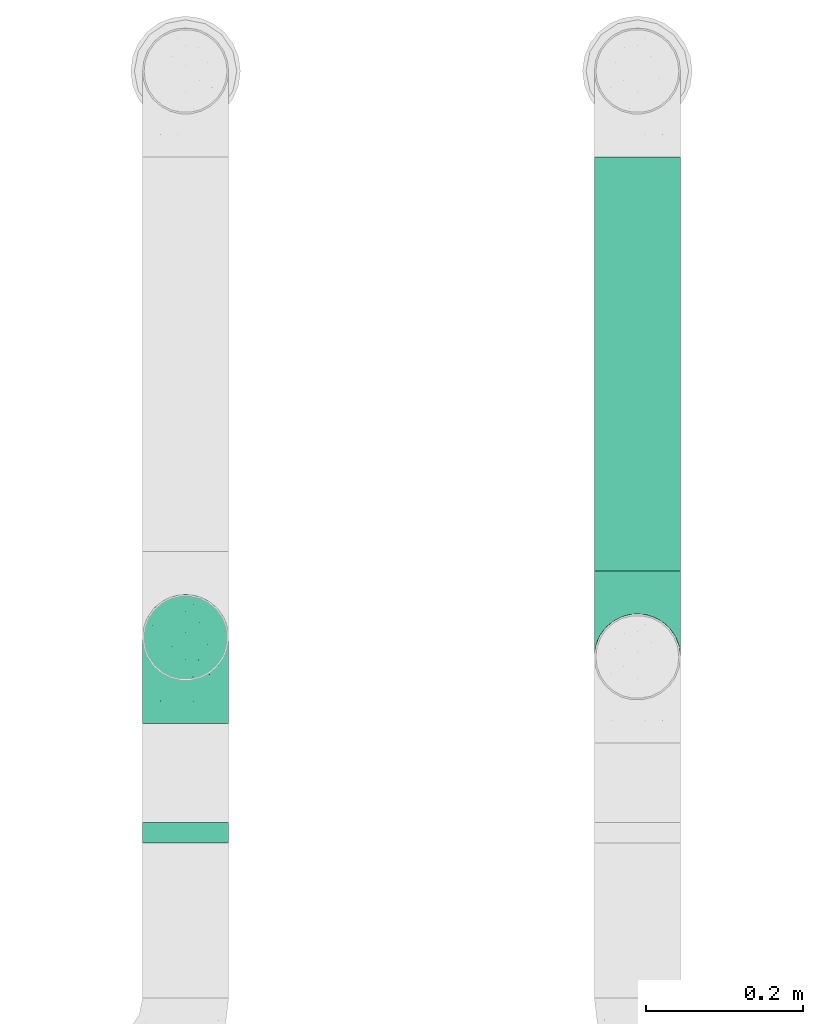
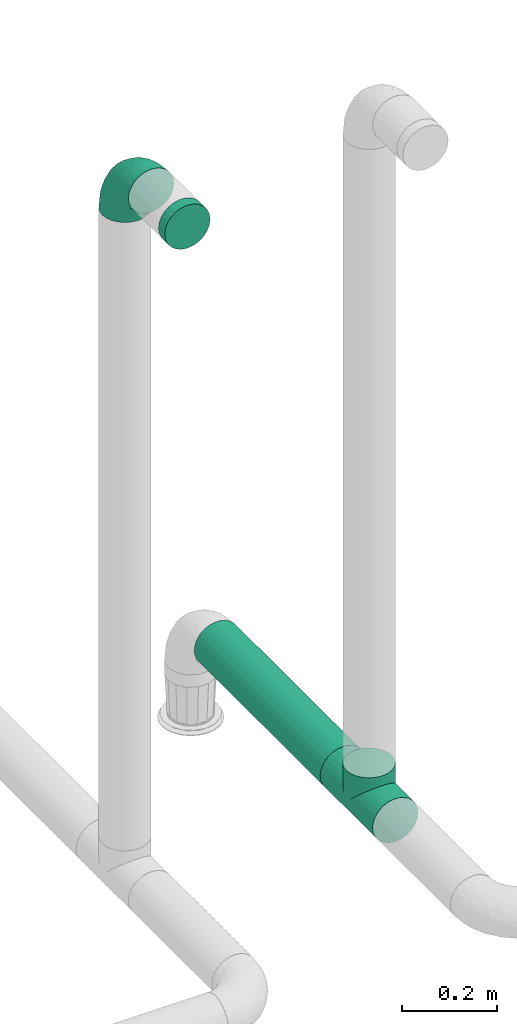
# One storey, part 59 of 103: 3 flow fittings, 1 flow segment.
"""IFC2X3 building model written with IfcOpenShell, lengths in millimetres."""

from ifc_helpers import new_model, entity, si_unit, converted_unit, derived_unit, direction, frame, origin_with_axes, origin_2d_with_axis, place, context, subcontext, project, spatial, hollow_circle, extrude, open_shell, surface_model, source, transform, mapped, material, layer, layer_set, layer_usage, type_object, element, save


model = new_model("IFC2X3")

# Units and contexts
model_context = context("Model", 3, precision=1e-05, world=origin_with_axes(), true_north=direction((0.0, 1.0)))
body_context = subcontext(model_context, "Body", "Model", "MODEL_VIEW")
ifc_project = project(units=[si_unit("AREAUNIT", "SQUARE_METRE"), si_unit("VOLUMEUNIT", "CUBIC_METRE", prefix="DECI"), si_unit("TIMEUNIT", "SECOND"), si_unit("THERMODYNAMICTEMPERATUREUNIT", "DEGREE_CELSIUS"), si_unit("PRESSUREUNIT", "PASCAL"), si_unit("MASSUNIT", "GRAM", prefix="KILO"), si_unit("LENGTHUNIT", "METRE", prefix="MILLI"), si_unit("POWERUNIT", "WATT"), si_unit("ELECTRICCURRENTUNIT", "AMPERE"), si_unit("ELECTRICVOLTAGEUNIT", "VOLT"), derived_unit("VOLUMETRICFLOWRATEUNIT", [(si_unit("VOLUMEUNIT", "CUBIC_METRE", prefix="DECI"), 1), (si_unit("TIMEUNIT", "SECOND"), -1)]), derived_unit("LINEARVELOCITYUNIT", [(si_unit("LENGTHUNIT", "METRE"), 1), (si_unit("TIMEUNIT", "SECOND"), -1)]), derived_unit("MASSDENSITYUNIT", [(si_unit("MASSUNIT", "GRAM", prefix="KILO"), 1), (si_unit("VOLUMEUNIT", "CUBIC_METRE"), -1)]), converted_unit("PLANEANGLEUNIT", "DEGREE", entity("IfcRatioMeasure", 0.01745), si_unit("PLANEANGLEUNIT", "RADIAN"), dimensions=[0, 0, 0, 0, 0, 0, 0])], contexts=[model_context])

# Site, building, storey
site_placement = place(None, origin_with_axes())
site = spatial("IfcSite", under=ifc_project, at=site_placement, CompositionType="ELEMENT")
building_placement = place(site_placement, origin_with_axes())
building = spatial("IfcBuilding", under=site, at=building_placement, Name="mc-building", CompositionType="ELEMENT")
storey_placement = place(building_placement, frame((0.0, 0.0, 5900.0), z_axis=(0.0, 0.0, 1.0), x_axis=(1.0, 0.0, 0.0)))
storey = spatial("IfcBuildingStorey", under=building, at=storey_placement, Name="3. Korrus", CompositionType="ELEMENT", Elevation=5900.0)

# Flow fitting
duct_fitting_type_1 = type_object("IfcDuctFittingType", PredefinedType="JUNCTION")
shared_shape_1 = source(origin_with_axes(), body_context, "Body", "SurfaceModel", [
    surface_model("IfcShellBasedSurfaceModel", [(0.0, -80.0, -55.0), (14.23505, -80.0, -53.12592), (-14.23505, -80.0, -53.12592), (-53.12592, -80.0, 14.23505), (-27.5, -80.0, -47.63139), (-47.63139, -80.0, -27.5), (-38.89087, -80.0, -38.89087), (55.0, -80.0, 0.0), (53.12592, -80.0, 14.23505), (38.89087, -80.0, -38.89087), (27.5, -80.0, -47.63139), (53.12592, -80.0, -14.23505), (47.63139, -80.0, -27.5), (-53.12592, -80.0, -14.23505), (-47.63139, -80.0, 27.5), (-38.89087, -80.0, 38.89087), (14.23505, -80.0, 53.12592), (-27.5, -80.0, 47.63139), (-14.23505, -80.0, 53.12592), (47.63139, -80.0, 27.5), (38.89087, -80.0, 38.89087), (27.5, -80.0, 47.63139), (0.0, -80.0, 55.0), (-55.0, -80.0, 0.0), (0.0, 0.0, 55.0), (-7.4066, -7.4066, 54.49901), (-14.74521, -14.74521, 52.98659), (-21.93978, -21.93978, 50.43457), (-28.89905, -28.89905, 46.79578), (-35.50357, -35.50357, 42.00591), (-41.58668, -41.58668, 35.99373), (-46.92319, -46.92319, 28.69171), (-51.19777, -51.19777, 20.0945), (-50.37866, -80.0, 20.86752), (-54.01174, -54.01174, 10.37938), (-55.0, -55.0, 0.0), (-54.06296, -80.0, 7.11752), (-54.01174, -54.01174, -10.37938), (-51.19777, -51.19777, -20.0945), (-54.06296, -80.0, -7.11752), (-46.92319, -46.92319, -28.69171), (-41.58668, -41.58668, -35.99373), (-50.37866, -80.0, -20.86752), (-35.50357, -35.50357, -42.00591), (-21.93978, -21.93978, -50.43457), (-14.74521, -14.74521, -52.98659), (-7.4066, -7.4066, -54.49901), (0.0, 0.0, -55.0), (-28.89905, -28.89905, -46.79578), (7.4066, -7.4066, -54.49901), (14.74521, -14.74521, -52.98659), (21.93978, -21.93978, -50.43457), (28.89905, -28.89905, -46.79578), (35.50357, -35.50357, -42.00591), (41.58668, -41.58668, -35.99373), (46.92319, -46.92319, -28.69171), (51.19777, -51.19777, -20.0945), (50.37866, -80.0, -20.86752), (54.01174, -54.01174, -10.37938), (55.0, -55.0, 0.0), (54.06296, -80.0, -7.11752), (54.01174, -54.01174, 10.37938), (51.19777, -51.19777, 20.0945), (54.06296, -80.0, 7.11752), (46.92319, -46.92319, 28.69171), (41.58668, -41.58668, 35.99373), (50.37866, -80.0, 20.86752), (35.50357, -35.50357, 42.00591), (21.93978, -21.93978, 50.43457), (14.74521, -14.74521, 52.98659), (7.4066, -7.4066, 54.49901), (28.89905, -28.89905, 46.79578), (-110.0, 0.0, -55.0), (-110.0, -14.23505, -53.12592), (-110.0, 14.23505, -53.12592), (-110.0, 53.12592, 14.23505), (-110.0, 27.5, -47.63139), (-110.0, 47.63139, -27.5), (-110.0, 38.89087, -38.89087), (-110.0, -55.0, 0.0), (-110.0, -53.12592, 14.23505), (-110.0, -38.89087, -38.89087), (-110.0, -27.5, -47.63139), (-110.0, -53.12592, -14.23505), (-110.0, -47.63139, -27.5), (-110.0, 53.12592, -14.23505), (-110.0, 47.63139, 27.5), (-110.0, 38.89087, 38.89087), (-110.0, -14.23505, 53.12592), (-110.0, 27.5, 47.63139), (-110.0, 14.23505, 53.12592), (-110.0, -47.63139, 27.5), (-110.0, -38.89087, 38.89087), (-110.0, -27.5, 47.63139), (-110.0, 0.0, 55.0), (-110.0, 55.0, 0.0), (110.0, 55.0, 0.0), (110.0, 0.0, -55.0), (110.0, 14.23505, -53.12592), (110.0, 27.5, -47.63139), (110.0, 38.89087, -38.89087), (110.0, 47.63139, -27.5), (110.0, -38.89087, -38.89087), (110.0, -53.12592, 14.23505), (110.0, -27.5, -47.63139), (110.0, -14.23505, -53.12592), (110.0, -47.63139, -27.5), (110.0, -53.12592, -14.23505), (110.0, -55.0, 0.0), (110.0, 53.12592, -14.23505), (110.0, 53.12592, 14.23505), (110.0, 47.63139, 27.5), (110.0, 38.89087, 38.89087), (110.0, 0.0, 55.0), (110.0, 27.5, 47.63139), (110.0, 14.23505, 53.12592), (110.0, -47.63139, 27.5), (110.0, -38.89087, 38.89087), (110.0, -27.5, 47.63139), (110.0, -14.23505, 53.12592)], [open_shell([[[0, 1, 2]], [[2, 3, 4]], [[5, 6, 3]], [[6, 4, 3]], [[2, 7, 8]], [[9, 7, 10]], [[1, 10, 7]], [[11, 7, 12]], [[9, 12, 7]], [[7, 2, 1]], [[5, 3, 13]], [[2, 14, 3]], [[2, 15, 14]], [[2, 16, 17]], [[17, 15, 2]], [[16, 18, 17]], [[2, 8, 19]], [[2, 19, 20]], [[2, 20, 21]], [[16, 2, 21]], [[16, 22, 18]], [[23, 13, 3]], [[24, 25, 22]], [[26, 27, 18]], [[25, 26, 18]], [[22, 25, 18]], [[17, 28, 29]], [[17, 18, 27]], [[17, 29, 15]], [[28, 17, 27]], [[30, 31, 14]], [[32, 3, 33]], [[32, 34, 3]], [[35, 36, 34]], [[31, 32, 14]], [[15, 30, 14]], [[34, 36, 3]], [[33, 14, 32]], [[36, 35, 23]], [[30, 15, 29]], [[37, 38, 13]], [[37, 13, 39]], [[40, 41, 5]], [[38, 5, 42]], [[38, 40, 5]], [[37, 39, 35]], [[35, 39, 23]], [[13, 38, 42]], [[41, 6, 5]], [[41, 43, 6]], [[44, 45, 2]], [[46, 47, 0]], [[45, 46, 2]], [[43, 48, 4]], [[44, 4, 48]], [[44, 2, 4]], [[46, 0, 2]], [[43, 4, 6]], [[47, 49, 0]], [[50, 51, 1]], [[49, 50, 1]], [[0, 49, 1]], [[10, 52, 53]], [[10, 1, 51]], [[10, 53, 9]], [[52, 10, 51]], [[54, 55, 12]], [[56, 11, 57]], [[56, 58, 11]], [[59, 60, 58]], [[55, 56, 12]], [[9, 54, 12]], [[58, 60, 11]], [[57, 12, 56]], [[60, 59, 7]], [[54, 9, 53]], [[61, 62, 8]], [[61, 8, 63]], [[64, 65, 19]], [[62, 19, 66]], [[62, 64, 19]], [[61, 63, 59]], [[7, 59, 63]], [[62, 66, 8]], [[65, 20, 19]], [[65, 67, 20]], [[68, 69, 16]], [[70, 24, 22]], [[69, 70, 16]], [[67, 71, 21]], [[68, 21, 71]], [[68, 16, 21]], [[70, 22, 16]], [[67, 21, 20]], [[72, 73, 74]], [[74, 75, 76]], [[77, 78, 75]], [[76, 75, 78]], [[74, 79, 80]], [[81, 79, 82]], [[73, 82, 79]], [[83, 79, 84]], [[81, 84, 79]], [[79, 74, 73]], [[77, 75, 85]], [[74, 86, 75]], [[74, 87, 86]], [[74, 88, 89]], [[89, 87, 74]], [[88, 90, 89]], [[74, 91, 92]], [[91, 74, 80]], [[92, 93, 74]], [[74, 93, 88]], [[88, 94, 90]], [[95, 85, 75]], [[96, 97, 98]], [[99, 96, 98]], [[96, 100, 101]], [[100, 96, 99]], [[102, 97, 103]], [[97, 102, 104]], [[104, 105, 97]], [[102, 103, 106]], [[106, 103, 107]], [[108, 107, 103]], [[109, 96, 101]], [[110, 111, 97]], [[97, 111, 112]], [[113, 97, 114]], [[97, 112, 114]], [[113, 114, 115]], [[116, 103, 97]], [[117, 116, 97]], [[118, 117, 97]], [[119, 118, 97]], [[119, 97, 113]], [[96, 110, 97]], [[24, 113, 115]], [[89, 115, 114]], [[94, 24, 90]], [[90, 24, 115]], [[115, 89, 90]], [[114, 87, 89]], [[86, 112, 111]], [[75, 111, 110]], [[95, 110, 96]], [[87, 112, 86]], [[86, 111, 75]], [[110, 95, 75]], [[112, 87, 114]], [[85, 96, 109]], [[77, 109, 101]], [[95, 96, 85]], [[85, 109, 77]], [[101, 78, 77]], [[101, 100, 78]], [[76, 100, 99]], [[74, 99, 98]], [[47, 98, 97]], [[76, 99, 74]], [[47, 72, 74]], [[98, 47, 74]], [[100, 76, 78]], [[47, 46, 72]], [[45, 44, 73]], [[46, 45, 73]], [[72, 46, 73]], [[82, 48, 43]], [[82, 73, 44]], [[82, 43, 81]], [[48, 82, 44]], [[41, 40, 84]], [[38, 37, 83]], [[40, 38, 84]], [[81, 41, 84]], [[37, 79, 83]], [[83, 84, 38]], [[79, 37, 35]], [[41, 81, 43]], [[49, 97, 105]], [[105, 104, 51]], [[53, 104, 102]], [[53, 52, 104]], [[49, 47, 97]], [[51, 50, 105]], [[52, 51, 104]], [[49, 105, 50]], [[54, 102, 106]], [[56, 106, 107]], [[58, 107, 108]], [[55, 54, 106]], [[58, 56, 107]], [[59, 58, 108]], [[55, 106, 56]], [[102, 54, 53]], [[34, 32, 80]], [[31, 30, 91]], [[32, 31, 91]], [[35, 34, 79]], [[80, 79, 34]], [[32, 91, 80]], [[30, 92, 91]], [[30, 29, 92]], [[27, 26, 88]], [[25, 24, 94]], [[26, 25, 88]], [[29, 28, 93]], [[27, 93, 28]], [[27, 88, 93]], [[25, 94, 88]], [[29, 93, 92]], [[61, 108, 103]], [[62, 103, 116]], [[65, 116, 117]], [[61, 59, 108]], [[64, 62, 116]], [[65, 64, 116]], [[61, 103, 62]], [[117, 67, 65]], [[71, 67, 118]], [[118, 67, 117]], [[68, 118, 119]], [[70, 119, 113]], [[68, 71, 118]], [[70, 69, 119]], [[24, 70, 113]], [[68, 119, 69]]])]),
])
flow_fitting_1_placement = place(storey_placement, frame((26665.96154, 3982.48523, 2345.0), z_axis=(-1.0, 0.0, 0.0), x_axis=(0.0, 1.0, 0.0)))
element("IfcFlowFitting", 1, at=flow_fitting_1_placement, inside=storey, type_object=duct_fitting_type_1, context=body_context, shape_type="MappedRepresentation", body=[
    mapped(shared_shape_1, transform((0.0, 0.0, 0.0), scale=1.0)),
])

# Flow segment
ifc_material = material(Name="FZ1")
ifc_layer = layer(ifc_material, 0.0)
ifc_layer_set = layer_set([ifc_layer], Name="FZ1")
ifc_layer_usage = layer_usage(ifc_layer_set, "AXIS1", "POSITIVE", 0.0)
duct_segment_type = type_object("IfcDuctSegmentType", Name="Safe", PredefinedType="RIGIDSEGMENT")
shared_shape_2 = source(origin_with_axes(), body_context, "Body", "SweptSolid", [
    extrude(hollow_circle(Radius=55.0, WallThickness=2.0, at=origin_2d_with_axis()), frame((0.0, 0.0, 0.0), z_axis=(1.0, 0.0, 0.0), x_axis=(0.0, 1.0, 0.0)), (0.0, 0.0, 1.0), 528.4),
])
flow_segment_placement = place(storey_placement, frame((26665.96154, 4092.48523, 2345.0), z_axis=(0.0, 0.0, 1.0), x_axis=(0.0, 1.0, 0.0)))
element("IfcFlowSegment", 2, at=flow_segment_placement, inside=storey, type_object=duct_segment_type, material=ifc_layer_usage, Name="Safe", context=body_context, shape_type="MappedRepresentation", body=[
    mapped(shared_shape_2, transform((0.0, 0.0, 0.0), scale=1.0)),
])

# Flow fittings
duct_fitting_type_2 = type_object("IfcDuctFittingType", Name="BU", PredefinedType="BEND")
shared_shape_3 = source(origin_with_axes(), body_context, "Body", "SurfaceModel", [
    surface_model("IfcShellBasedSurfaceModel", [(-110.0, 0.0, -55.0), (-110.0, -14.23505, -53.12592), (-110.0, 14.23505, -53.12592), (-110.0, 53.12592, 14.23505), (-110.0, 27.5, -47.63139), (-110.0, 38.89087, -38.89087), (-110.0, -55.0, 0.0), (-110.0, -53.12592, 14.23505), (-110.0, -38.89087, -38.89087), (-110.0, -27.5, -47.63139), (-110.0, -53.12592, -14.23505), (-110.0, -47.63139, -27.5), (-110.0, -14.23505, 53.12592), (-110.0, 14.23505, 53.12592), (-110.0, 27.5, 47.63139), (-110.0, -47.63139, 27.5), (-110.0, -38.89087, 38.89087), (-110.0, -27.5, 47.63139), (-110.0, 0.0, 55.0), (-110.0, 55.0, 0.0), (-110.0, 53.12592, -14.23505), (-110.0, 47.63139, -27.5), (-110.0, 47.63139, 27.5), (-110.0, 38.89087, 38.89087), (-14.23505, 110.0, -53.12592), (-55.0, 110.0, 0.0), (0.0, 110.0, -55.0), (-27.5, 110.0, -47.63139), (-38.89087, 110.0, -38.89087), (-47.63139, 110.0, -27.5), (38.89087, 110.0, -38.89087), (53.12592, 110.0, 14.23505), (27.5, 110.0, -47.63139), (14.23505, 110.0, -53.12592), (47.63139, 110.0, -27.5), (53.12592, 110.0, -14.23505), (55.0, 110.0, 0.0), (-53.12592, 110.0, -14.23505), (-53.12592, 110.0, 14.23505), (-47.63139, 110.0, 27.5), (-38.89087, 110.0, 38.89087), (-27.5, 110.0, 47.63139), (0.0, 110.0, 55.0), (-14.23505, 110.0, 53.12592), (38.89087, 110.0, 38.89087), (47.63139, 110.0, 27.5), (27.5, 110.0, 47.63139), (14.23505, 110.0, 53.12592), (-64.21732, 48.68956, 43.63444), (-76.6405, 38.18013, 45.55988), (-60.44912, 32.56953, 51.94617), (-76.00813, 5.38378, 55.0), (-90.15553, 11.94394, 54.09138), (-78.5998, 26.77405, 50.81338), (-70.18771, 18.55163, 54.03432), (-75.55424, 54.2118, 32.41257), (-93.27622, 45.77614, 33.48188), (-96.12334, 22.13664, 50.81337), (-21.00813, 45.34362, 55.0), (-18.36258, 70.48427, 54.04484), (-32.04182, 59.64019, 52.24446), (-63.88653, 74.77858, 17.99134), (-74.66383, 63.08407, 19.92123), (-63.60674, 66.07878, 29.97482), (-99.597, 52.72185, 18.52927), (-93.11138, 56.59448, 10.50359), (-98.21577, 57.34403, 0.0), (-53.42855, 92.60092, 21.04759), (-88.54852, 54.8376, 21.04759), (-11.86161, 90.23965, 54.10313), (-5.38378, 76.00813, 55.0), (-57.34403, 98.21577, 0.0), (-56.64619, 93.12774, 10.22088), (-45.34362, 21.00813, 55.0), (-44.60838, 44.60838, 52.13415), (-92.68484, 35.46673, 43.63443), (-22.25266, 95.40765, 50.81337), (-35.97783, 90.61597, 43.63443), (-43.70931, 69.58671, 44.47149), (-27.23711, 77.39884, 50.81337), (-57.2828, 79.3123, 24.9774), (-58.67786, 84.31125, 16.04456), (-82.93277, 60.36161, 12.91784), (-49.88337, 54.51816, 47.224), (-74.57753, 66.83759, 9.55742), (-45.35812, 94.97281, 33.48188), (-59.18663, 88.95241, 0.0), (-51.517, 78.6292, 33.48188), (-65.14788, 80.03077, 0.0), (-56.45322, 62.06476, 39.63545), (-88.95241, 59.18663, 0.0), (-71.10913, 71.10913, 0.0), (-80.03077, 65.14788, 0.0), (-94.9309, 45.36788, -33.48188), (-93.11358, 56.60141, -10.46614), (-99.64997, 52.79499, -18.30015), (-90.20425, 36.08686, -43.63443), (-79.99933, 46.56772, -37.92748), (-76.00813, 5.38378, -55.0), (-72.75364, 19.68651, -53.60527), (-45.34362, 21.00813, -55.0), (-21.91957, 65.12078, -53.85897), (-5.38378, 76.00813, -55.0), (-21.00813, 45.34362, -55.0), (-35.41876, 92.89265, -43.63443), (-91.10309, 11.02766, -54.21832), (-45.77614, 93.27622, -33.48188), (-90.50474, 23.21022, -50.81337), (-70.92854, 33.31794, -49.51754), (-78.52933, 63.35627, -11.73997), (-24.91508, 84.05606, -50.81337), (-88.78941, 54.74452, -21.04759), (-69.59921, 57.34866, -33.48187), (-73.36422, 62.46673, -22.94182), (-63.49062, 67.59111, -28.46929), (-56.59448, 93.11138, -10.50359), (-54.8376, 88.54852, -21.04759), (-54.10679, 75.85581, -32.31867), (-57.75956, 31.09612, -52.80882), (-52.72185, 99.597, -18.52927), (-12.62913, 89.46304, -53.99097), (-34.46825, 66.46123, -50.04329), (-43.9837, 43.9837, -52.42279), (-65.78527, 72.58348, -17.68796), (-70.34468, 43.65295, -44.21951), (-57.47001, 51.99467, -44.91465), (-60.72547, 82.29174, -12.88567), (-42.34915, 74.24548, -43.63444), (-57.25194, 63.5016, -38.08211), (-80.95344, 53.56991, -29.32027), (-52.32891, 4.55257, -54.0482), (32.52942, 47.13398, -30.48571), (14.88266, 20.92917, -33.7947), (14.95561, 36.05775, -42.26543), (30.24048, 70.09027, -41.7461), (19.3559, 65.35825, -48.00507), (-70.35075, -46.44478, -19.5952), (-47.13398, -32.52942, -30.48571), (-28.49299, -30.5778, -16.4009), (-4.55257, 52.32891, -54.0482), (-22.4954, 22.4954, -53.25347), (-75.47368, -11.22546, -52.60718), (-81.32209, -51.5606, -9.98467), (-80.81763, -41.84862, -32.14655), (-70.09027, -30.24048, -41.7461), (-36.05774, -14.95561, -42.26543), (-9.15831, -10.852, -27.8997), (-65.35825, -19.3559, -48.00507), (11.22546, 75.47368, -52.60718), (3.94376, 43.9333, -50.53315), (-13.39742, 13.39743, -48.13058), (-43.9333, -3.94376, -50.53315), (49.37776, 67.29486, 0.0), (41.8609, 47.82256, -9.92641), (50.20582, 74.51695, -9.9731), (18.93131, 11.7156, -17.56239), (-27.5, -32.89419, 0.0), (-1.23348, -12.25375, -12.18106), (41.84862, 80.81763, -32.14655), (35.70604, 41.31408, -20.38235), (46.44478, 70.35075, -19.5952), (32.89419, 27.5, 0.0), (6.67262, -6.67262, 0.0), (-67.29486, -49.37776, 0.0), (-50.36265, -42.95545, -9.51562), (-5.47251, 5.47251, -39.92906), (-70.35075, -46.44478, 19.5952), (-74.51695, -50.20582, 9.9731), (-41.31407, -35.70604, 20.38235), (-47.13398, -32.52942, 30.48571), (-80.81763, -41.84862, 32.14655), (-4.55257, 52.32891, 54.0482), (11.22546, 75.47368, 52.60718), (-43.9333, -3.94376, 50.53315), (-65.35825, -19.3559, 48.00507), (-36.05774, -14.95561, 42.26543), (-70.09027, -30.24048, 41.7461), (-11.7156, -18.93131, 17.56239), (30.5778, 28.49299, 16.4009), (12.25375, 1.23348, 12.18106), (51.5606, 81.32209, 9.98467), (42.95545, 50.36265, 9.51562), (-75.47368, -11.22546, 52.60718), (-52.32891, 4.55257, 54.0482), (3.94376, 43.9333, 50.53315), (-22.4954, 22.4954, 53.25347), (-13.39742, 13.39743, 48.13058), (10.852, 9.15831, 27.8997), (-20.92916, -14.88266, 33.79469), (-47.82256, -41.8609, 9.92641), (32.52942, 47.13398, 30.48571), (46.44478, 70.35075, 19.5952), (41.84862, 80.81763, 32.14655), (30.24048, 70.09027, 41.7461), (19.3559, 65.35825, 48.00507), (14.95561, 36.05775, 42.26543), (-5.47251, 5.47251, 39.92906)], [open_shell([[[0, 1, 2]], [[2, 3, 4]], [[4, 3, 5]], [[2, 6, 7]], [[8, 6, 9]], [[1, 9, 6]], [[10, 6, 11]], [[8, 11, 6]], [[6, 2, 1]], [[12, 13, 14]], [[15, 2, 7]], [[16, 17, 2]], [[2, 17, 12]], [[12, 18, 13]], [[19, 20, 3]], [[5, 3, 21]], [[20, 21, 3]], [[22, 3, 2]], [[23, 22, 2]], [[12, 14, 2]], [[2, 14, 23]], [[15, 16, 2]], [[24, 25, 26]], [[27, 25, 24]], [[25, 28, 29]], [[28, 25, 27]], [[30, 26, 31]], [[26, 30, 32]], [[32, 33, 26]], [[34, 31, 35]], [[31, 34, 30]], [[35, 31, 36]], [[29, 37, 25]], [[38, 39, 26]], [[39, 40, 26]], [[41, 42, 40]], [[42, 26, 40]], [[42, 41, 43]], [[26, 44, 45]], [[31, 26, 45]], [[26, 46, 44]], [[47, 46, 26]], [[42, 47, 26]], [[25, 38, 26]], [[48, 49, 50]], [[18, 51, 52]], [[53, 54, 50]], [[55, 56, 49]], [[56, 22, 23]], [[13, 57, 14]], [[58, 59, 60]], [[61, 62, 63]], [[3, 64, 65]], [[53, 52, 54]], [[3, 65, 66]], [[67, 39, 38]], [[56, 68, 64]], [[65, 64, 68]], [[69, 59, 70]], [[38, 71, 72]], [[73, 58, 74]], [[75, 49, 56]], [[76, 69, 43]], [[53, 57, 52]], [[77, 78, 79]], [[41, 76, 43]], [[43, 69, 42]], [[55, 68, 56]], [[23, 14, 75]], [[76, 77, 79]], [[80, 67, 81]], [[62, 82, 68]], [[60, 78, 83]], [[62, 84, 82]], [[85, 77, 40]], [[81, 67, 72]], [[86, 72, 71]], [[87, 85, 67]], [[61, 81, 88]], [[77, 41, 40]], [[78, 77, 87]], [[23, 75, 56]], [[83, 89, 48]], [[85, 40, 39]], [[62, 68, 55]], [[89, 87, 63]], [[83, 48, 50]], [[57, 75, 14]], [[49, 75, 53]], [[67, 85, 39]], [[87, 77, 85]], [[63, 62, 55]], [[89, 55, 48]], [[80, 63, 87]], [[66, 65, 90]], [[66, 19, 3]], [[84, 91, 92]], [[92, 90, 82]], [[65, 82, 90]], [[61, 84, 62]], [[92, 82, 84]], [[68, 82, 65]], [[3, 22, 64]], [[56, 64, 22]], [[38, 25, 71]], [[81, 72, 86]], [[38, 72, 67]], [[91, 61, 88]], [[80, 81, 61]], [[63, 80, 61]], [[67, 80, 87]], [[77, 76, 41]], [[79, 59, 69]], [[79, 69, 76]], [[42, 69, 70]], [[60, 59, 79]], [[58, 70, 59]], [[78, 60, 79]], [[58, 60, 74]], [[52, 57, 13]], [[75, 57, 53]], [[18, 52, 13]], [[52, 51, 54]], [[51, 73, 54]], [[50, 73, 74]], [[73, 50, 54]], [[50, 74, 83]], [[60, 83, 74]], [[89, 83, 78]], [[87, 89, 78]], [[55, 89, 63]], [[50, 49, 53]], [[55, 49, 48]], [[81, 86, 88]], [[91, 84, 61]], [[5, 21, 93]], [[90, 94, 66]], [[20, 94, 95]], [[96, 93, 97]], [[98, 99, 100]], [[96, 4, 5]], [[101, 102, 103]], [[28, 27, 104]], [[2, 105, 0]], [[104, 106, 28]], [[99, 105, 107]], [[108, 107, 96]], [[90, 109, 94]], [[107, 2, 4]], [[20, 66, 94]], [[27, 24, 110]], [[109, 111, 94]], [[112, 113, 114]], [[37, 115, 71]], [[116, 106, 117]], [[99, 118, 100]], [[116, 115, 119]], [[37, 119, 115]], [[24, 120, 110]], [[121, 110, 101]], [[119, 106, 116]], [[101, 110, 120]], [[122, 103, 100]], [[117, 123, 116]], [[124, 125, 108]], [[115, 116, 126]], [[106, 29, 28]], [[26, 102, 120]], [[127, 104, 110]], [[97, 124, 96]], [[125, 122, 118]], [[128, 127, 125]], [[96, 5, 93]], [[115, 126, 86]], [[117, 106, 127]], [[111, 113, 129]], [[95, 93, 21]], [[97, 129, 112]], [[110, 104, 27]], [[106, 104, 127]], [[96, 107, 4]], [[99, 107, 108]], [[99, 108, 118]], [[105, 99, 98]], [[112, 114, 128]], [[121, 125, 127]], [[20, 19, 66]], [[109, 90, 92]], [[94, 111, 95]], [[91, 123, 109]], [[129, 113, 112]], [[93, 95, 111]], [[21, 20, 95]], [[71, 115, 86]], [[71, 25, 37]], [[123, 91, 88]], [[126, 116, 123]], [[123, 88, 126]], [[86, 126, 88]], [[37, 29, 119]], [[106, 119, 29]], [[129, 93, 111]], [[124, 112, 125]], [[0, 105, 98]], [[107, 105, 2]], [[125, 118, 108]], [[100, 118, 122]], [[93, 129, 97]], [[113, 111, 109]], [[109, 123, 113]], [[114, 123, 117]], [[123, 114, 113]], [[128, 114, 117]], [[127, 128, 117]], [[112, 128, 125]], [[103, 122, 101]], [[110, 121, 127]], [[101, 122, 121]], [[125, 121, 122]], [[26, 120, 24]], [[101, 120, 102]], [[96, 124, 108]], [[92, 91, 109]], [[112, 124, 97]], [[100, 130, 98]], [[131, 132, 133]], [[32, 134, 135]], [[136, 137, 138]], [[139, 140, 103]], [[98, 141, 0]], [[142, 10, 136]], [[143, 144, 137]], [[6, 10, 142]], [[137, 145, 146]], [[144, 147, 145]], [[143, 136, 11]], [[11, 136, 10]], [[8, 143, 11]], [[148, 149, 139]], [[8, 9, 144]], [[9, 1, 147]], [[130, 141, 98]], [[103, 140, 100]], [[148, 135, 149]], [[150, 151, 140]], [[152, 153, 154]], [[130, 140, 151]], [[148, 26, 33]], [[147, 1, 141]], [[155, 146, 132]], [[156, 138, 157]], [[134, 30, 158]], [[150, 140, 149]], [[158, 30, 34]], [[30, 134, 32]], [[153, 159, 160]], [[131, 160, 159]], [[144, 145, 137]], [[36, 152, 154]], [[146, 138, 137]], [[155, 161, 162]], [[158, 160, 131]], [[133, 149, 135]], [[156, 163, 164]], [[163, 142, 164]], [[139, 103, 102]], [[153, 152, 161]], [[34, 35, 160]], [[162, 157, 155]], [[132, 165, 133]], [[157, 146, 155]], [[140, 130, 100]], [[141, 130, 151]], [[141, 151, 147]], [[141, 1, 0]], [[102, 26, 148]], [[140, 139, 149]], [[102, 148, 139]], [[135, 33, 32]], [[151, 150, 145]], [[9, 147, 144]], [[151, 145, 147]], [[145, 165, 146]], [[135, 148, 33]], [[133, 135, 134]], [[131, 133, 134]], [[133, 165, 150]], [[133, 150, 149]], [[145, 150, 165]], [[132, 131, 159]], [[146, 165, 132]], [[160, 158, 34]], [[134, 158, 131]], [[144, 143, 8]], [[136, 143, 137]], [[155, 153, 161]], [[154, 153, 160]], [[153, 155, 159]], [[132, 159, 155]], [[160, 35, 154]], [[36, 154, 35]], [[164, 136, 138]], [[6, 142, 163]], [[136, 164, 142]], [[156, 164, 138]], [[156, 157, 162]], [[146, 157, 138]], [[15, 7, 166]], [[6, 163, 167]], [[168, 169, 166]], [[166, 169, 170]], [[171, 172, 70]], [[173, 174, 175]], [[17, 176, 174]], [[177, 156, 162]], [[176, 16, 170]], [[170, 16, 15]], [[161, 178, 179]], [[152, 180, 181]], [[182, 173, 183]], [[18, 12, 182]], [[184, 185, 186]], [[183, 185, 73]], [[183, 73, 51]], [[177, 187, 188]], [[189, 168, 166]], [[187, 178, 190]], [[16, 176, 17]], [[161, 152, 181]], [[45, 191, 31]], [[45, 44, 192]], [[192, 191, 45]], [[180, 36, 31]], [[193, 194, 195]], [[46, 47, 194]], [[193, 195, 190]], [[193, 44, 46]], [[172, 42, 70]], [[185, 58, 73]], [[189, 163, 156]], [[163, 189, 167]], [[70, 58, 171]], [[184, 171, 185]], [[169, 188, 175]], [[180, 31, 191]], [[192, 193, 190]], [[191, 190, 178]], [[182, 174, 173]], [[194, 47, 172]], [[190, 195, 187]], [[186, 185, 173]], [[162, 179, 177]], [[188, 196, 175]], [[179, 187, 177]], [[185, 171, 58]], [[172, 171, 184]], [[172, 184, 194]], [[172, 47, 42]], [[51, 18, 182]], [[185, 183, 173]], [[51, 182, 183]], [[174, 12, 17]], [[184, 186, 195]], [[46, 194, 193]], [[184, 195, 194]], [[195, 196, 187]], [[174, 182, 12]], [[175, 174, 176]], [[169, 175, 176]], [[175, 196, 186]], [[175, 186, 173]], [[195, 186, 196]], [[188, 169, 168]], [[187, 196, 188]], [[166, 170, 15]], [[176, 170, 169]], [[193, 192, 44]], [[191, 192, 190]], [[177, 189, 156]], [[167, 189, 166]], [[189, 177, 168]], [[188, 168, 177]], [[166, 7, 167]], [[6, 167, 7]], [[181, 191, 178]], [[36, 180, 152]], [[191, 181, 180]], [[161, 181, 178]], [[161, 179, 162]], [[187, 179, 178]]])]),
])
flow_fitting_2_placement = place(storey_placement, frame((26088.96136, 4007.31628, 4144.0), z_axis=(1.0, 0.0, 0.0), x_axis=(0.0, 0.0, 1.0)))
element("IfcFlowFitting", 3, at=flow_fitting_2_placement, inside=storey, type_object=duct_fitting_type_2, Name="BU", context=body_context, shape_type="MappedRepresentation", body=[
    mapped(shared_shape_3, transform((0.0, 0.0, 0.0), scale=1.0)),
])
duct_fitting_type_3 = type_object("IfcDuctFittingType", Name="CC", PredefinedType="CONNECTOR")
shared_shape_4 = source(origin_with_axes(), body_context, "Body", "SurfaceModel", [
    surface_model("IfcShellBasedSurfaceModel", [(-6.096, -55.0, 0.0), (-6.096, 0.0, -55.0), (-6.096, -14.23505, -53.12592), (-6.096, -27.5, -47.63139), (-6.096, -38.89087, -38.89087), (-6.096, -47.63139, -27.5), (-6.096, 38.89087, -38.89087), (-6.096, 53.12592, 14.23505), (-6.096, 27.5, -47.63139), (-6.096, 14.23505, -53.12592), (-6.096, 47.63139, -27.5), (-6.096, 53.12592, -14.23505), (-6.096, 55.0, 0.0), (-6.096, -53.12592, -14.23505), (-6.096, -53.12592, 14.23505), (-6.096, -47.63139, 27.5), (-6.096, -38.89087, 38.89087), (-6.096, 0.0, 55.0), (-6.096, -27.5, 47.63139), (-6.096, -14.23505, 53.12592), (-6.096, 38.89087, 38.89087), (-6.096, 47.63139, 27.5), (-6.096, 14.23505, 53.12592), (-6.096, 27.5, 47.63139), (0.0, -14.23505, 53.12592), (0.0, 0.0, 55.0), (0.0, -27.5, 47.63139), (0.0, -38.89087, 38.89087), (0.0, -53.12592, 14.23505), (0.0, -47.63139, 27.5), (0.0, -55.0, 0.0), (0.0, -53.12592, -14.23505), (0.0, -47.63139, -27.5), (0.0, -38.89087, -38.89087), (0.0, -14.23505, -53.12592), (0.0, -27.5, -47.63139), (0.0, 0.0, -55.0), (0.0, 14.23505, -53.12592), (0.0, 27.5, -47.63139), (0.0, 38.89087, -38.89087), (0.0, 53.12592, -14.23505), (0.0, 47.63139, -27.5), (0.0, 55.0, 0.0), (0.0, 53.12592, 14.23505), (0.0, 47.63139, 27.5), (0.0, 38.89087, 38.89087), (0.0, 14.23505, 53.12592), (0.0, 27.5, 47.63139), (20.0, 0.0, -55.0), (20.0, 14.23505, -53.12592), (20.0, -14.23505, -53.12592), (20.0, -53.12592, 14.23505), (20.0, -27.5, -47.63139), (20.0, -47.63139, -27.5), (20.0, -38.89087, -38.89087), (20.0, 55.0, 0.0), (20.0, 53.12592, 14.23505), (20.0, 38.89087, -38.89087), (20.0, 27.5, -47.63139), (20.0, 53.12592, -14.23505), (20.0, 47.63139, -27.5), (20.0, -53.12592, -14.23505), (20.0, -47.63139, 27.5), (20.0, -38.89087, 38.89087), (20.0, 14.23505, 53.12592), (20.0, -27.5, 47.63139), (20.0, -14.23505, 53.12592), (20.0, 47.63139, 27.5), (20.0, 38.89087, 38.89087), (20.0, 27.5, 47.63139), (20.0, 0.0, 55.0), (20.0, -55.0, 0.0)], [open_shell([[[0, 1, 2]], [[3, 0, 2]], [[0, 4, 5]], [[4, 0, 3]], [[6, 1, 7]], [[1, 6, 8]], [[8, 9, 1]], [[6, 7, 10]], [[10, 7, 11]], [[12, 11, 7]], [[13, 0, 5]], [[14, 15, 1]], [[1, 15, 16]], [[17, 16, 18]], [[17, 1, 16]], [[19, 17, 18]], [[20, 21, 1]], [[7, 1, 21]], [[22, 23, 1]], [[23, 20, 1]], [[22, 1, 17]], [[0, 14, 1]], [[24, 25, 17]], [[26, 24, 19]], [[19, 24, 17]], [[16, 27, 18]], [[26, 19, 18]], [[26, 18, 27]], [[28, 29, 15]], [[30, 28, 14]], [[15, 29, 16]], [[28, 15, 14]], [[30, 14, 0]], [[27, 16, 29]], [[31, 30, 0]], [[32, 31, 13]], [[13, 31, 0]], [[4, 33, 5]], [[32, 13, 5]], [[32, 5, 33]], [[34, 35, 3]], [[36, 34, 2]], [[3, 35, 4]], [[34, 3, 2]], [[36, 2, 1]], [[33, 4, 35]], [[37, 36, 1]], [[38, 37, 9]], [[9, 37, 1]], [[6, 39, 8]], [[38, 9, 8]], [[38, 8, 39]], [[40, 41, 10]], [[42, 40, 11]], [[10, 41, 6]], [[40, 10, 11]], [[42, 11, 12]], [[39, 6, 41]], [[43, 42, 12]], [[44, 43, 7]], [[7, 43, 12]], [[20, 45, 21]], [[44, 7, 21]], [[44, 21, 45]], [[46, 47, 23]], [[25, 46, 22]], [[23, 47, 20]], [[46, 23, 22]], [[25, 22, 17]], [[45, 20, 47]], [[48, 49, 50]], [[50, 51, 52]], [[53, 54, 51]], [[52, 51, 54]], [[50, 55, 56]], [[57, 55, 58]], [[49, 58, 55]], [[59, 55, 60]], [[57, 60, 55]], [[55, 50, 49]], [[53, 51, 61]], [[50, 62, 51]], [[63, 62, 50]], [[64, 65, 50]], [[65, 63, 50]], [[64, 66, 65]], [[50, 67, 68]], [[67, 50, 56]], [[68, 69, 50]], [[50, 69, 64]], [[64, 70, 66]], [[71, 61, 51]], [[66, 70, 25]], [[65, 66, 24]], [[24, 66, 25]], [[27, 63, 26]], [[65, 24, 26]], [[65, 26, 63]], [[51, 62, 29]], [[71, 51, 28]], [[29, 62, 27]], [[51, 29, 28]], [[71, 28, 30]], [[63, 27, 62]], [[61, 71, 30]], [[53, 61, 31]], [[31, 61, 30]], [[33, 54, 32]], [[53, 31, 32]], [[53, 32, 54]], [[50, 52, 35]], [[48, 50, 34]], [[35, 52, 33]], [[50, 35, 34]], [[48, 34, 36]], [[54, 33, 52]], [[49, 48, 36]], [[58, 49, 37]], [[37, 49, 36]], [[39, 57, 38]], [[58, 37, 38]], [[58, 38, 57]], [[59, 60, 41]], [[55, 59, 40]], [[41, 60, 39]], [[59, 41, 40]], [[55, 40, 42]], [[57, 39, 60]], [[56, 55, 42]], [[67, 56, 43]], [[43, 56, 42]], [[45, 68, 44]], [[67, 43, 44]], [[67, 44, 68]], [[64, 69, 47]], [[70, 64, 46]], [[47, 69, 45]], [[64, 47, 46]], [[70, 46, 25]], [[68, 45, 69]], [[50, 63, 62]], [[50, 64, 65]], [[50, 56, 67]], [[50, 68, 69]], [[64, 50, 69]]])]),
])
flow_fitting_3_placement = place(storey_placement, frame((26088.96136, 3751.20513, 4144.0), z_axis=(0.0, 0.0, -1.0), x_axis=(0.0, 1.0, 0.0)))
element("IfcFlowFitting", 4, at=flow_fitting_3_placement, inside=storey, type_object=duct_fitting_type_3, Name="CC", context=body_context, shape_type="MappedRepresentation", body=[
    mapped(shared_shape_4, transform((0.0, 0.0, 0.0), scale=1.0)),
])

save(model, "model.ifc")
